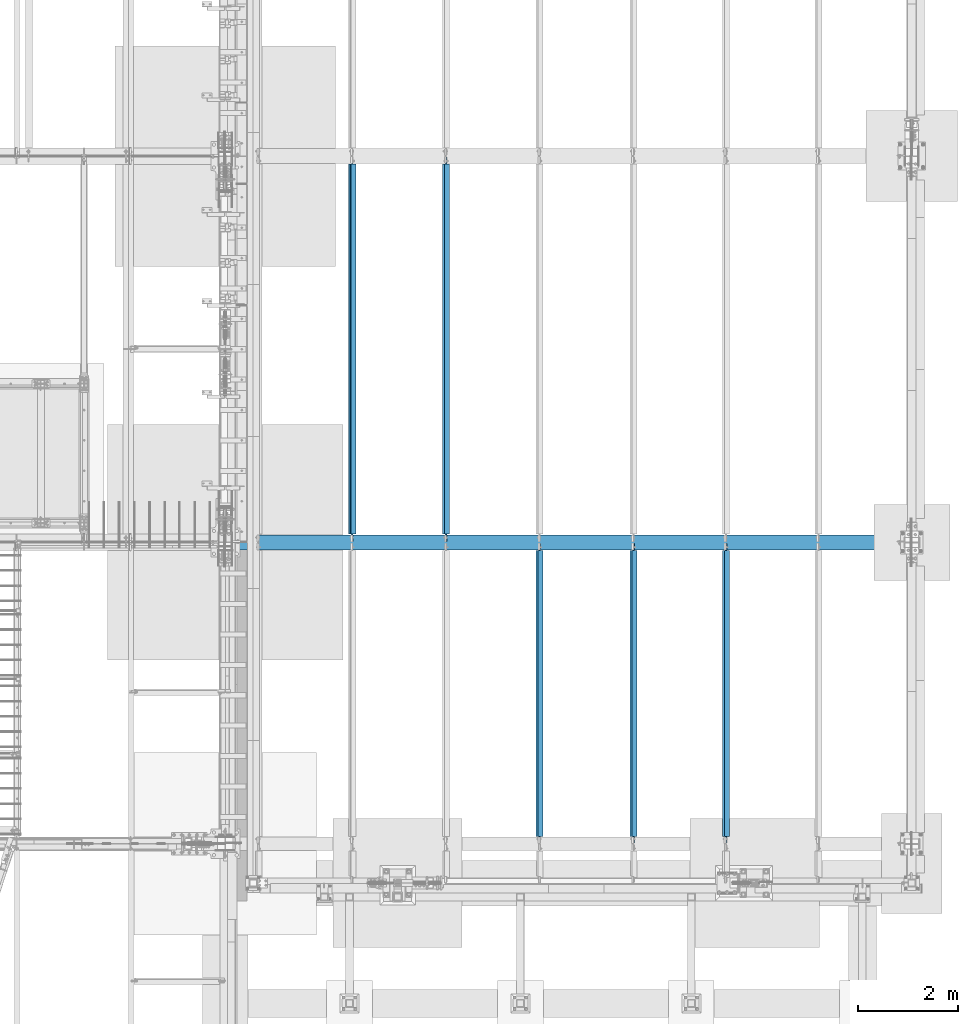
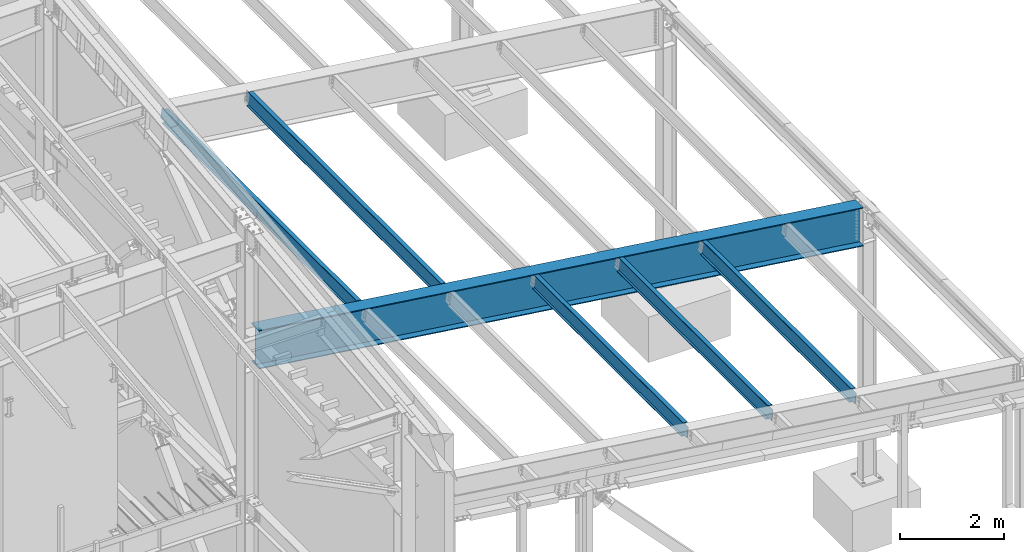
# One storey, part 747 of 1179: 6 beams, 6 elements without a shape of their own.
"""IFC2X3 building model written with IfcOpenShell, lengths in millimetres."""

import ifcopenshell
import ifcopenshell.guid

model = None  # the IFC model being written
_history = None  # IfcOwnerHistory: only IFC2X3 demands one
_inside = {}  # id of a spatial element -> (the spatial element, [elements in it])
_under = {}  # id of a project, library or spatial element -> (it, [spatial elements below it])
_declared = {}  # id of a project -> (the project, [libraries it declares])
_typed = {}  # id of a type object -> (the type object, [elements of that type])
_made_of = {}  # id of a material, layer set ... -> (it, [elements and type objects made of it])


def new_model(schema):
    """Start an empty IFC model of exactly this schema.

    Asked for "IFC4X3", IfcOpenShell would pick the latest addendum, in which some entities
    have other attributes; the version numbers below select the first issue.
    IFC2X3 requires an IfcOwnerHistory on every rooted entity: one is made here for all.
    """
    global model, _history
    if schema == "IFC4X3":
        model = ifcopenshell.file(schema_version=(4, 3, 0, 0))
    else:
        model = ifcopenshell.file(schema=schema)
    _inside.clear()
    _under.clear()
    _declared.clear()
    _typed.clear()
    _made_of.clear()
    _history = None
    if model.schema == "IFC2X3":
        org = make("IfcOrganization", Name="unknown")
        user = make(
            "IfcPersonAndOrganization",
            ThePerson=make("IfcPerson", FamilyName="unknown"),
            TheOrganization=org,
        )
        app = make(
            "IfcApplication",
            ApplicationDeveloper=org,
            Version="unknown",
            ApplicationFullName="unknown",
            ApplicationIdentifier="unknown",
        )
        _history = make(
            "IfcOwnerHistory",
            OwningUser=user,
            OwningApplication=app,
            ChangeAction="ADDED",
            CreationDate=0,
        )
    return model


def make(cls, **values):
    """One entity of the class cls with the attributes given. An attribute that is None is left unset."""
    return model.create_entity(
        cls, **{name: value for name, value in values.items() if value is not None}
    )


def rooted(cls, **values):
    """An entity with a GlobalId (a new one), such as an element, a storey or a relation."""
    return make(cls, GlobalId=ifcopenshell.guid.new(), OwnerHistory=_history, **values)


def si_unit(unit_type, name, prefix=None):
    """IfcSIUnit, for example si_unit("LENGTHUNIT", "METRE", prefix="MILLI")."""
    return make("IfcSIUnit", UnitType=unit_type, Prefix=prefix, Name=name)


def assignment(units):
    """IfcUnitAssignment: the units of a project."""
    return None if units is None else make("IfcUnitAssignment", Units=units)


def point(xyz):
    """IfcCartesianPoint."""
    return None if xyz is None else make("IfcCartesianPoint", Coordinates=xyz)


def direction(xyz):
    """IfcDirection."""
    return None if xyz is None else make("IfcDirection", DirectionRatios=xyz)


def frame(location, z_axis=None, x_axis=None):
    """IfcAxis2Placement3D, a coordinate frame: its origin and axes. An axis left out is left unset."""
    return make(
        "IfcAxis2Placement3D",
        Location=point(location),
        Axis=direction(z_axis),
        RefDirection=direction(x_axis),
    )


def origin_with_axes():
    """The frame at (0, 0, 0) with the z axis (0, 0, 1) and the x axis (1, 0, 0) written out."""
    return frame((0.0, 0.0, 0.0), z_axis=(0.0, 0.0, 1.0), x_axis=(1.0, 0.0, 0.0))


def place(relative_to, where):
    """IfcLocalPlacement: puts the frame where relative to a parent placement (None: the world)."""
    return make(
        "IfcLocalPlacement", PlacementRelTo=relative_to, RelativePlacement=where
    )


def context(
    kind, dimensions, precision=None, world=None, true_north=None, identifier=None
):
    """IfcGeometricRepresentationContext, for example the 3D "Model" context."""
    return make(
        "IfcGeometricRepresentationContext",
        ContextIdentifier=identifier,
        ContextType=kind,
        CoordinateSpaceDimension=dimensions,
        Precision=precision,
        WorldCoordinateSystem=world,
        TrueNorth=true_north,
    )


def subcontext(parent, identifier, kind, view, scale=None):
    """IfcGeometricRepresentationSubContext, for example "Body" below "Model"."""
    return make(
        "IfcGeometricRepresentationSubContext",
        ContextIdentifier=identifier,
        ContextType=kind,
        ParentContext=parent,
        TargetScale=scale,
        TargetView=view,
    )


def project(units=None, contexts=None):
    """IfcProject with its units and contexts."""
    return rooted(
        "IfcProject",
        Name="project",
        RepresentationContexts=contexts,
        UnitsInContext=assignment(units),
    )


def spatial(cls, under=None, at=None, **own):
    """A site, building, storey or space (cls), placed at a placement, below another one or the project."""
    s = rooted(cls, ObjectPlacement=at, **own)
    if under is not None:
        _under.setdefault(under.id(), (under, []))[1].append(s)
    return s


def faces_of(points, faces, orient=None, outer=None):
    """IfcFace entities. A face is a list of loops; a loop is a list of indices into points, from 0.

    orient and outer hold one flag for each loop. By default every Orientation is true, the
    first loop of a face is its IfcFaceOuterBound and the others are IfcFaceBound.
    """
    made = []
    for i, loops in enumerate(faces):
        bounds = []
        for j, loop in enumerate(loops):
            is_outer = j == 0 if outer is None else outer[i][j]
            bounds.append(
                make(
                    "IfcFaceOuterBound" if is_outer else "IfcFaceBound",
                    Bound=make("IfcPolyLoop", Polygon=[points[k] for k in loop]),
                    Orientation=True if orient is None else orient[i][j],
                )
            )
        made.append(make("IfcFace", Bounds=bounds))
    return made


def faceted_brep(points, faces, orient=None, outer=None, voids=None):
    """IfcFacetedBrep: a solid bounded by flat faces; with voids (closed shells), ...WithVoids."""
    shared = [point(p) for p in points]
    hull = make("IfcClosedShell", CfsFaces=faces_of(shared, faces, orient, outer))
    if voids is None:
        return make("IfcFacetedBrep", Outer=hull)
    return make(
        "IfcFacetedBrepWithVoids",
        Outer=hull,
        Voids=[
            make(cls, CfsFaces=faces_of(shared, fs, o, b)) for cls, fs, o, b in voids
        ],
    )


def shape(context_of_items, identifier, shape_type, items):
    """IfcShapeRepresentation: the items that make up one representation, for example the "Body"."""
    return make(
        "IfcShapeRepresentation",
        ContextOfItems=context_of_items,
        RepresentationIdentifier=identifier,
        RepresentationType=shape_type,
        Items=items,
    )


def material(Name=None, Category=None):
    """IfcMaterial."""
    return make("IfcMaterial", Name=Name, Category=Category)


def made_of(thing, what):
    """Note that an element or type object is made of a material, layer set ...; save() writes the relation."""
    if what is not None:
        _made_of.setdefault(what.id(), (what, []))[1].append(thing)
    return thing


def type_object(cls, material=None, **own):
    """A type object (cls), such as IfcWallType, which elements share."""
    return made_of(rooted(cls, **own), material)


def element(
    cls,
    number,
    at=None,
    inside=None,
    cuts=None,
    type_object=None,
    material=None,
    context=None,
    identifier="Body",
    shape_type=None,
    held_by="IfcProductDefinitionShape",
    body=None,
    shapes=None,
    **own,
):
    """One element of the class cls, such as IfcWall. Its Tag is "e" and its number.

    at: its placement. inside: the storey or other place that contains it. cuts: it is an
    opening in that element (IfcRelVoidsElement). A single representation is given by context,
    identifier, shape_type and body (its items); several are given by shapes. held_by: the class
    of the entity that holds the representations. save() writes the other relations.
    """
    e = rooted(cls, Tag="e%d" % number, ObjectPlacement=at, **own)
    if body is not None:
        shapes = [shape(context, identifier, shape_type, body)]
    if shapes is not None:
        e.Representation = make(held_by, Representations=shapes)
    if inside is not None:
        _inside.setdefault(inside.id(), (inside, []))[1].append(e)
    if cuts is not None:
        rooted(
            "IfcRelVoidsElement", RelatingBuildingElement=cuts, RelatedOpeningElement=e
        )
    if type_object is not None:
        _typed.setdefault(type_object.id(), (type_object, []))[1].append(e)
    return made_of(e, material)


def aggregate(whole, parts):
    """IfcRelAggregates: a whole, such as a stair, and the parts it consists of."""
    return rooted("IfcRelAggregates", RelatingObject=whole, RelatedObjects=parts)


def save(model, path):
    """Write the relations noted so far, then the file.

    IfcRelAggregates (storeys below a building ...), IfcRelContainedInSpatialStructure (elements
    in a storey), IfcRelDefinesByType, IfcRelAssociatesMaterial and IfcRelDeclares: one each for
    every whole, place, type object, material and project.
    """
    for whole, parts in _under.values():
        aggregate(whole, parts)
    for where, things in _inside.values():
        rooted(
            "IfcRelContainedInSpatialStructure",
            RelatedElements=things,
            RelatingStructure=where,
        )
    for kind, things in _typed.values():
        rooted("IfcRelDefinesByType", RelatedObjects=things, RelatingType=kind)
    for what, things in _made_of.values():
        rooted("IfcRelAssociatesMaterial", RelatedObjects=things, RelatingMaterial=what)
    for by, libraries in _declared.values():
        rooted("IfcRelDeclares", RelatingContext=by, RelatedDefinitions=libraries)
    model.write(path)


model = new_model("IFC2X3")

# Units and contexts
model_context = context("Model", 3, precision=1e-05, world=origin_with_axes())
body_context = subcontext(model_context, "Body", "Model", "MODEL_VIEW")
ifc_project = project(units=[si_unit("LENGTHUNIT", "METRE", prefix="MILLI"), si_unit("AREAUNIT", "SQUARE_METRE"), si_unit("VOLUMEUNIT", "CUBIC_METRE"), si_unit("MASSUNIT", "GRAM", prefix="KILO"), si_unit("TIMEUNIT", "SECOND"), si_unit("PLANEANGLEUNIT", "RADIAN"), si_unit("SOLIDANGLEUNIT", "STERADIAN"), si_unit("THERMODYNAMICTEMPERATUREUNIT", "DEGREE_CELSIUS"), si_unit("LUMINOUSINTENSITYUNIT", "LUMEN")], contexts=[model_context])

# Site, building, storey
site_placement = place(None, origin_with_axes())
site = spatial("IfcSite", under=ifc_project, at=site_placement, CompositionType="ELEMENT")
building_placement = place(site_placement, origin_with_axes())
building = spatial("IfcBuilding", under=site, at=building_placement, Name="Undefined", CompositionType="ELEMENT")
storey_placement = place(building_placement, origin_with_axes())
storey = spatial("IfcBuildingStorey", under=building, at=storey_placement, Name="Undefined", CompositionType="ELEMENT", Elevation=0.0)

# Assembly, beam
assembly_1_placement = place(storey_placement, origin_with_axes())
assembly_1 = element("IfcElementAssembly", 1, at=assembly_1_placement, inside=storey, Name="BEAM", AssemblyPlace="NOTDEFINED", PredefinedType="RIGID_FRAME")
ifc_material = material(Name="STEEL/A992")
beam_type_1 = type_object("IfcBeamType", Name="W12X22", PredefinedType="NOTDEFINED")
beam_1_placement = place(assembly_1_placement, frame((30611.5820076832, 5435.6, 7028.46481116712), z_axis=(0.133813223953133, 0.0, 0.991006569652931), x_axis=(0.0, 1.0, 0.0)))
beam_1 = element("IfcBeam", 2, at=beam_1_placement, type_object=beam_type_1, material=ifc_material, Name="BEAM", ObjectType="W12X22", context=body_context, shape_type="Brep", body=[
    faceted_brep([(5880.09999999999, -3.17499999983193, -144.462500000051), (5880.09999999999, -50.7999999998428, -144.462500000063), (5880.09999999999, -50.7999999998283, -155.575000000068), (5880.09999999999, 50.8000000001921, -155.575000000041), (5880.09999999999, 50.8000000001848, -144.462500000036), (5880.09999999999, 3.17500000017026, -144.462500000049), (5880.09999999999, 3.17500000016298, -136.52499982221), (5880.09999999999, -3.17499999983556, -136.524999822204), (5881.06672992258, 3.17500000015571, -131.66492030416), (5881.06672992258, -3.17499999984648, -131.664920304156), (5883.81974382306, 3.17500000015207, -127.544743836002), (5883.81974382306, -3.17499999985012, -127.544743835997), (5887.93992029121, 3.17500000014843, -124.791729935519), (5887.93992029121, -3.17499999985375, -124.791729935516), (5892.79999980926, 3.17500000014843, -123.825000012932), (5892.79999980926, -3.17499999985375, -123.825000012926), (6024.5625, -3.17499999985375, -123.825000012823), (6024.5625, 3.17500000014479, -123.825000012814), (144.4625, 3.17499999983193, 144.462500000049), (144.4625, 50.7999999998428, 144.462500000061), (5880.09999999999, 50.7999999998428, 144.462500000061), (5880.09999999999, 3.17499999983193, 144.462500000049), (146.049999999999, -3.1749999998392, -136.524999805057), (146.049999999999, 3.17500000015934, -136.52499980506), (146.049999999999, 3.17500000017026, -144.462500000049), (146.049999999999, 50.8000000001848, -144.462500000036), (146.049999999999, 50.8000000001921, -155.575000000041), (146.049999999999, -50.7999999998283, -155.575000000068), (146.049999999999, -50.7999999998428, -144.462500000063), (146.049999999999, -3.17499999983193, -144.462500000051), (145.083270077412, -3.17499999984284, -131.664920287005), (145.083270077412, 3.17500000015571, -131.664920287008), (142.330256176933, -3.17499999985012, -127.544743818849), (142.330256176933, 3.17500000015207, -127.544743818851), (138.21007970878, -3.17499999985375, -124.791729918366), (138.21007970878, 3.17500000014479, -124.791729918372), (133.350000190734, -3.17499999985375, -123.824999995779), (133.350000190734, 3.17500000014843, -123.824999995781), (19.0500000000002, -3.17499999985375, -123.824999995893), (19.0500000000002, 3.17500000014843, -123.824999995886), (19.0500000000002, -3.17500000013752, 117.475000004351), (19.0500000000002, 3.17499999986467, 117.475000004359), (131.762500190734, -3.17500000013752, 117.47500000447), (131.762500190734, 3.17499999986467, 117.475000004464), (136.62257970878, -3.17500000013752, 118.441729927057), (136.62257970878, 3.17499999986103, 118.441729927054), (140.742756176934, -3.17500000014115, 121.194743827538), (140.742756176934, 3.17499999986103, 121.194743827535), (143.495770077412, -3.17500000014479, 125.314920295696), (143.495770077412, 3.17499999985375, 125.314920295692), (144.4625, -3.17500000015571, 130.174999813746), (144.4625, 3.17499999984648, 130.174999813742), (144.4625, -50.8000000001921, 155.575000000039), (144.4625, 50.7999999998283, 155.575000000066), (144.4625, -3.17500000016662, 144.462500000047), (144.4625, -50.8000000001812, 144.462500000034), (5880.09999999999, -3.17500000016662, 144.462500000047), (5880.09999999999, -50.8000000001812, 144.462500000034), (5880.09999999999, -50.8000000001921, 155.575000000039), (5880.09999999999, 50.7999999998283, 155.575000000066), (5880.09999999999, -3.17500000015207, 130.17499979644), (5880.09999999999, 3.17499999985012, 130.174999796436), (5881.06672992258, -3.17500000014843, 125.314920278392), (5881.06672992258, 3.17499999985012, 125.314920278386), (5883.81974382306, -3.17500000014479, 121.194743810232), (5883.81974382306, 3.17499999985739, 121.194743810229), (5887.93992029121, -3.17500000013752, 118.441729909751), (5887.93992029121, 3.17499999986103, 118.441729909748), (5892.79999980926, -3.17500000013752, 117.474999987164), (5892.79999980926, 3.17499999986467, 117.474999987158), (6024.5625, -3.17500000013752, 117.474999987267), (6024.5625, 3.17499999986467, 117.474999987275)], [[[0, 1, 2, 3, 4, 5, 6, 7]], [[7, 6, 8, 9]], [[9, 8, 10, 11]], [[11, 10, 12, 13]], [[13, 12, 14, 15]], [[16, 15, 14, 17]], [[18, 19, 20, 21]], [[22, 23, 24, 25, 26, 27, 28, 29]], [[30, 31, 23, 22]], [[32, 33, 31, 30]], [[34, 35, 33, 32]], [[36, 37, 35, 34]], [[38, 39, 37, 36]], [[40, 41, 39, 38]], [[42, 43, 41, 40]], [[44, 45, 43, 42]], [[46, 47, 45, 44]], [[48, 49, 47, 46]], [[50, 51, 49, 48]], [[52, 53, 19, 18, 51, 50, 54, 55]], [[55, 54, 56, 57]], [[52, 55, 57, 58]], [[53, 52, 58, 59]], [[19, 53, 59, 20]], [[58, 57, 56, 60, 61, 21, 20, 59]], [[62, 63, 61, 60]], [[64, 65, 63, 62]], [[66, 67, 65, 64]], [[68, 69, 67, 66]], [[70, 71, 69, 68]], [[71, 70, 16, 17]], [[12, 10, 8, 6, 5, 24, 23, 31, 33, 35, 37, 39, 41, 43, 45, 47, 49, 51, 18, 21, 61, 63, 65, 67, 69, 71, 17, 14]], [[25, 24, 5, 4]], [[26, 25, 4, 3]], [[27, 26, 3, 2]], [[28, 27, 2, 1]], [[29, 28, 1, 0]], [[70, 68, 66, 64, 62, 60, 56, 54, 50, 48, 46, 44, 42, 40, 38, 36, 34, 32, 30, 22, 29, 0, 7, 9, 11, 13, 15, 16]]]),
])
aggregate(assembly_1, [beam_1])

assembly_2_placement = place(storey_placement, origin_with_axes())
assembly_2 = element("IfcElementAssembly", 3, at=assembly_2_placement, inside=storey, Name="BEAM", AssemblyPlace="NOTDEFINED", PredefinedType="RIGID_FRAME")
beam_2_placement = place(assembly_2_placement, frame((32491.1820076831, 5435.6, 6774.66696214919), z_axis=(0.133813223953133, 0.0, 0.991006569652931), x_axis=(0.0, 1.0, 0.0)))
beam_2 = element("IfcBeam", 4, at=beam_2_placement, type_object=beam_type_1, material=ifc_material, Name="BEAM", ObjectType="W12X22", context=body_context, shape_type="Brep", body=[
    faceted_brep([(5880.09999999999, -3.17499999983193, -144.462500000051), (5880.09999999999, -50.7999999998428, -144.462500000063), (5880.09999999999, -50.7999999998283, -155.575000000068), (5880.09999999999, 50.8000000001921, -155.575000000041), (5880.09999999999, 50.8000000001848, -144.462500000036), (5880.09999999999, 3.17500000017026, -144.462500000049), (5880.09999999999, 3.17500000016298, -136.52499982221), (5880.09999999999, -3.17499999983556, -136.524999822204), (5881.06672992258, 3.17500000015571, -131.66492030416), (5881.06672992258, -3.17499999984648, -131.664920304156), (5883.81974382306, 3.17500000015207, -127.544743836002), (5883.81974382306, -3.17499999985012, -127.544743835997), (5887.93992029121, 3.17500000014843, -124.791729935519), (5887.93992029121, -3.17499999985375, -124.791729935516), (5892.79999980926, 3.17500000014843, -123.825000012932), (5892.79999980926, -3.17499999985375, -123.825000012926), (6024.5625, -3.17499999985375, -123.825000012823), (6024.5625, 3.17500000014479, -123.825000012814), (144.4625, 3.17499999983193, 144.462500000049), (144.4625, 50.7999999998428, 144.462500000061), (5880.09999999999, 50.7999999998428, 144.462500000061), (5880.09999999999, 3.17499999983193, 144.462500000049), (146.049999999999, -3.1749999998392, -136.524999805057), (146.049999999999, 3.17500000015934, -136.52499980506), (146.049999999999, 3.17500000017026, -144.462500000049), (146.049999999999, 50.8000000001848, -144.462500000036), (146.049999999999, 50.8000000001921, -155.575000000041), (146.049999999999, -50.7999999998283, -155.575000000068), (146.049999999999, -50.7999999998428, -144.462500000063), (146.049999999999, -3.17499999983193, -144.462500000051), (145.083270077412, -3.17499999984284, -131.664920287005), (145.083270077412, 3.17500000015571, -131.664920287008), (142.330256176933, -3.17499999985012, -127.544743818849), (142.330256176933, 3.17500000015207, -127.544743818851), (138.21007970878, -3.17499999985375, -124.791729918366), (138.21007970878, 3.17500000014479, -124.791729918372), (133.350000190734, -3.17499999985375, -123.824999995779), (133.350000190734, 3.17500000014843, -123.824999995781), (19.0500000000002, -3.17499999985375, -123.824999995893), (19.0500000000002, 3.17500000014843, -123.824999995886), (19.0500000000002, -3.17500000013752, 117.475000004351), (19.0500000000002, 3.17499999986467, 117.475000004359), (131.762500190734, -3.17500000013752, 117.47500000447), (131.762500190734, 3.17499999986467, 117.475000004464), (136.62257970878, -3.17500000013752, 118.441729927057), (136.62257970878, 3.17499999986103, 118.441729927054), (140.742756176934, -3.17500000014115, 121.194743827538), (140.742756176934, 3.17499999986103, 121.194743827535), (143.495770077412, -3.17500000014479, 125.314920295696), (143.495770077412, 3.17499999985375, 125.314920295692), (144.4625, -3.17500000015571, 130.174999813746), (144.4625, 3.17499999984648, 130.174999813742), (144.4625, -50.8000000001921, 155.575000000039), (144.4625, 50.7999999998283, 155.575000000066), (144.4625, -3.17500000016662, 144.462500000047), (144.4625, -50.8000000001812, 144.462500000034), (5880.09999999999, -3.17500000016662, 144.462500000047), (5880.09999999999, -50.8000000001812, 144.462500000034), (5880.09999999999, -50.8000000001921, 155.575000000039), (5880.09999999999, 50.7999999998283, 155.575000000066), (5880.09999999999, -3.17500000015207, 130.17499979644), (5880.09999999999, 3.17499999985012, 130.174999796436), (5881.06672992258, -3.17500000014843, 125.314920278392), (5881.06672992258, 3.17499999985012, 125.314920278386), (5883.81974382306, -3.17500000014479, 121.194743810232), (5883.81974382306, 3.17499999985739, 121.194743810229), (5887.93992029121, -3.17500000013752, 118.441729909751), (5887.93992029121, 3.17499999986103, 118.441729909748), (5892.79999980926, -3.17500000013752, 117.474999987164), (5892.79999980926, 3.17499999986467, 117.474999987158), (6024.5625, -3.17500000013752, 117.474999987267), (6024.5625, 3.17499999986467, 117.474999987275)], [[[0, 1, 2, 3, 4, 5, 6, 7]], [[7, 6, 8, 9]], [[9, 8, 10, 11]], [[11, 10, 12, 13]], [[13, 12, 14, 15]], [[16, 15, 14, 17]], [[18, 19, 20, 21]], [[22, 23, 24, 25, 26, 27, 28, 29]], [[30, 31, 23, 22]], [[32, 33, 31, 30]], [[34, 35, 33, 32]], [[36, 37, 35, 34]], [[38, 39, 37, 36]], [[40, 41, 39, 38]], [[42, 43, 41, 40]], [[44, 45, 43, 42]], [[46, 47, 45, 44]], [[48, 49, 47, 46]], [[50, 51, 49, 48]], [[52, 53, 19, 18, 51, 50, 54, 55]], [[55, 54, 56, 57]], [[52, 55, 57, 58]], [[53, 52, 58, 59]], [[19, 53, 59, 20]], [[58, 57, 56, 60, 61, 21, 20, 59]], [[62, 63, 61, 60]], [[64, 65, 63, 62]], [[66, 67, 65, 64]], [[68, 69, 67, 66]], [[70, 71, 69, 68]], [[71, 70, 16, 17]], [[12, 10, 8, 6, 5, 24, 23, 31, 33, 35, 37, 39, 41, 43, 45, 47, 49, 51, 18, 21, 61, 63, 65, 67, 69, 71, 17, 14]], [[25, 24, 5, 4]], [[26, 25, 4, 3]], [[27, 26, 3, 2]], [[28, 27, 2, 1]], [[29, 28, 1, 0]], [[70, 68, 66, 64, 62, 60, 56, 54, 50, 48, 46, 44, 42, 40, 38, 36, 34, 32, 30, 22, 29, 0, 7, 9, 11, 13, 15, 16]]]),
])
aggregate(assembly_2, [beam_2])

assembly_3_placement = place(storey_placement, origin_with_axes())
assembly_3 = element("IfcElementAssembly", 5, at=assembly_3_placement, inside=storey, Name="BEAM", AssemblyPlace="NOTDEFINED", PredefinedType="RIGID_FRAME")
beam_3_placement = place(assembly_3_placement, frame((34345.3820076835, 5435.6, 6524.2988137938), z_axis=(0.133813223953133, 0.0, 0.991006569652931), x_axis=(0.0, 1.0, 0.0)))
beam_3 = element("IfcBeam", 6, at=beam_3_placement, type_object=beam_type_1, material=ifc_material, Name="BEAM", ObjectType="W12X22", context=body_context, shape_type="Brep", body=[
    faceted_brep([(5880.09999999999, -3.17499999983193, -144.462500000051), (5880.09999999999, -50.7999999998428, -144.462500000063), (5880.09999999999, -50.7999999998283, -155.575000000068), (5880.09999999999, 50.8000000001921, -155.575000000041), (5880.09999999999, 50.8000000001848, -144.462500000036), (5880.09999999999, 3.17500000017026, -144.462500000049), (5880.09999999999, 3.17500000016298, -136.52499982221), (5880.09999999999, -3.17499999983556, -136.524999822204), (5881.06672992258, 3.17500000015571, -131.66492030416), (5881.06672992258, -3.17499999984648, -131.664920304156), (5883.81974382306, 3.17500000015207, -127.544743836002), (5883.81974382306, -3.17499999985012, -127.544743835997), (5887.93992029121, 3.17500000014843, -124.791729935519), (5887.93992029121, -3.17499999985375, -124.791729935516), (5892.79999980926, 3.17500000014843, -123.825000012932), (5892.79999980926, -3.17499999985375, -123.825000012926), (6024.5625, -3.17499999985375, -123.825000012823), (6024.5625, 3.17500000014479, -123.825000012814), (144.4625, 3.17499999983193, 144.462500000049), (144.4625, 50.7999999998428, 144.462500000061), (5880.09999999999, 50.7999999998428, 144.462500000061), (5880.09999999999, 3.17499999983193, 144.462500000049), (146.049999999999, -3.1749999998392, -136.524999805057), (146.049999999999, 3.17500000015934, -136.52499980506), (146.049999999999, 3.17500000017026, -144.462500000049), (146.049999999999, 50.8000000001848, -144.462500000036), (146.049999999999, 50.8000000001921, -155.575000000041), (146.049999999999, -50.7999999998283, -155.575000000068), (146.049999999999, -50.7999999998428, -144.462500000063), (146.049999999999, -3.17499999983193, -144.462500000051), (145.083270077412, -3.17499999984284, -131.664920287005), (145.083270077412, 3.17500000015571, -131.664920287008), (142.330256176933, -3.17499999985012, -127.544743818849), (142.330256176933, 3.17500000015207, -127.544743818851), (138.21007970878, -3.17499999985375, -124.791729918366), (138.21007970878, 3.17500000014479, -124.791729918372), (133.350000190734, -3.17499999985375, -123.824999995779), (133.350000190734, 3.17500000014843, -123.824999995781), (19.0500000000002, -3.17499999985375, -123.824999995893), (19.0500000000002, 3.17500000014843, -123.824999995886), (19.0500000000002, -3.17500000013752, 117.475000004351), (19.0500000000002, 3.17499999986467, 117.475000004359), (131.762500190734, -3.17500000013752, 117.47500000447), (131.762500190734, 3.17499999986467, 117.475000004464), (136.62257970878, -3.17500000013752, 118.441729927057), (136.62257970878, 3.17499999986103, 118.441729927054), (140.742756176934, -3.17500000014115, 121.194743827538), (140.742756176934, 3.17499999986103, 121.194743827535), (143.495770077412, -3.17500000014479, 125.314920295696), (143.495770077412, 3.17499999985375, 125.314920295692), (144.4625, -3.17500000015571, 130.174999813746), (144.4625, 3.17499999984648, 130.174999813742), (144.4625, -50.8000000001921, 155.575000000039), (144.4625, 50.7999999998283, 155.575000000066), (144.4625, -3.17500000016662, 144.462500000047), (144.4625, -50.8000000001812, 144.462500000034), (5880.09999999999, -3.17500000016662, 144.462500000047), (5880.09999999999, -50.8000000001812, 144.462500000034), (5880.09999999999, -50.8000000001921, 155.575000000039), (5880.09999999999, 50.7999999998283, 155.575000000066), (5880.09999999999, -3.17500000015207, 130.17499979644), (5880.09999999999, 3.17499999985012, 130.174999796436), (5881.06672992258, -3.17500000014843, 125.314920278392), (5881.06672992258, 3.17499999985012, 125.314920278386), (5883.81974382306, -3.17500000014479, 121.194743810232), (5883.81974382306, 3.17499999985739, 121.194743810229), (5887.93992029121, -3.17500000013752, 118.441729909751), (5887.93992029121, 3.17499999986103, 118.441729909748), (5892.79999980926, -3.17500000013752, 117.474999987164), (5892.79999980926, 3.17499999986467, 117.474999987158), (6024.5625, -3.17500000013752, 117.474999987267), (6024.5625, 3.17499999986467, 117.474999987275)], [[[0, 1, 2, 3, 4, 5, 6, 7]], [[7, 6, 8, 9]], [[9, 8, 10, 11]], [[11, 10, 12, 13]], [[13, 12, 14, 15]], [[16, 15, 14, 17]], [[18, 19, 20, 21]], [[22, 23, 24, 25, 26, 27, 28, 29]], [[30, 31, 23, 22]], [[32, 33, 31, 30]], [[34, 35, 33, 32]], [[36, 37, 35, 34]], [[38, 39, 37, 36]], [[40, 41, 39, 38]], [[42, 43, 41, 40]], [[44, 45, 43, 42]], [[46, 47, 45, 44]], [[48, 49, 47, 46]], [[50, 51, 49, 48]], [[52, 53, 19, 18, 51, 50, 54, 55]], [[55, 54, 56, 57]], [[52, 55, 57, 58]], [[53, 52, 58, 59]], [[19, 53, 59, 20]], [[58, 57, 56, 60, 61, 21, 20, 59]], [[62, 63, 61, 60]], [[64, 65, 63, 62]], [[66, 67, 65, 64]], [[68, 69, 67, 66]], [[70, 71, 69, 68]], [[71, 70, 16, 17]], [[12, 10, 8, 6, 5, 24, 23, 31, 33, 35, 37, 39, 41, 43, 45, 47, 49, 51, 18, 21, 61, 63, 65, 67, 69, 71, 17, 14]], [[25, 24, 5, 4]], [[26, 25, 4, 3]], [[27, 26, 3, 2]], [[28, 27, 2, 1]], [[29, 28, 1, 0]], [[70, 68, 66, 64, 62, 60, 56, 54, 50, 48, 46, 44, 42, 40, 38, 36, 34, 32, 30, 22, 29, 0, 7, 9, 11, 13, 15, 16]]]),
])
aggregate(assembly_3, [beam_3])

assembly_4_placement = place(storey_placement, origin_with_axes())
assembly_4 = element("IfcElementAssembly", 7, at=assembly_4_placement, inside=storey, Name="BEAM", AssemblyPlace="NOTDEFINED", PredefinedType="RIGID_FRAME")
beam_4_placement = place(assembly_4_placement, frame((28731.9820076529, 11480.8, 7282.26266076169), z_axis=(0.133813223953133, 0.0, 0.991006569652931), x_axis=(0.0, 1.0, 0.0)))
beam_4 = element("IfcBeam", 8, at=beam_4_placement, type_object=beam_type_1, material=ifc_material, Name="BEAM", ObjectType="W12X22", context=body_context, shape_type="Brep", body=[
    faceted_brep([(7585.075, -3.17499999982829, -144.462500000047), (7585.075, -50.7999999998428, -144.46250000006), (7585.075, -50.7999999998356, -155.575000000064), (7585.075, 50.8000000001921, -155.575000000037), (7585.075, 50.8000000001775, -144.462500000032), (7585.075, 3.17500000017026, -144.462500000047), (7585.075, 3.17500000016298, -136.524999801413), (7585.075, -3.17499999984284, -136.52499980141), (7586.04172992259, 3.17500000014843, -131.664920283363), (7586.04172992259, -3.17499999984284, -131.66492028336), (7588.79474382307, 3.17500000014843, -127.544743815206), (7588.79474382307, -3.17499999985012, -127.544743815202), (7592.91492029122, 3.17500000014843, -124.791729914725), (7592.91492029122, -3.17499999985012, -124.791729914721), (7597.77499980927, 3.17500000014115, -123.824999992135), (7597.77499980927, -3.17499999985739, -123.824999992132), (7726.3625, -3.17499999985739, -123.824999992028), (7726.3625, 3.17500000014115, -123.824999992019), (165.100000000002, 3.17499999982829, 144.462500000052), (165.100000000002, 50.7999999998356, 144.462500000065), (7585.075, 50.7999999998356, 144.462500000065), (7585.075, 3.17499999982829, 144.462500000052), (165.100000000002, -3.17499999984284, -136.524999799762), (165.100000000002, 3.17500000016298, -136.524999799765), (165.100000000002, 3.17500000017026, -144.462500000047), (165.100000000002, 50.8000000001775, -144.462500000032), (165.100000000002, 50.8000000001921, -155.575000000037), (165.100000000002, -50.7999999998356, -155.575000000064), (165.100000000002, -50.7999999998428, -144.46250000006), (165.100000000002, -3.17499999982829, -144.462500000047), (164.133270077415, -3.17499999984284, -131.664920281712), (164.133270077415, 3.17500000014843, -131.664920281715), (161.380256176937, -3.17499999985739, -127.544743813552), (161.380256176937, 3.17500000014843, -127.544743813558), (157.260079708783, -3.17499999985739, -124.791729913073), (157.260079708783, 3.17500000014115, -124.791729913077), (152.400000190737, -3.17499999985739, -123.824999990484), (152.400000190737, 3.17500000014843, -123.824999990487), (20.6375000000044, -3.17499999985739, -123.824999990466), (20.6375000000044, 3.17500000014843, -123.824999990458), (20.6375000000044, -3.17500000014115, 117.475000009781), (20.6375000000044, 3.17499999986467, 117.475000009788), (152.400000190737, -3.17500000014115, 117.475000009763), (152.400000190737, 3.17499999985739, 117.475000009759), (157.260079708783, -3.17500000014115, 118.44172993235), (157.260079708783, 3.17499999986467, 118.441729932347), (161.380256176937, -3.17500000014115, 121.194743832832), (161.380256176937, 3.17499999985739, 121.194743832826), (164.133270077415, -3.17500000014843, 125.314920300991), (164.133270077415, 3.17499999985012, 125.314920300985), (165.100000000002, -3.17500000016298, 130.174999819041), (165.100000000002, 3.17499999984284, 130.174999819037), (165.100000000002, -50.8000000001994, 155.575000000043), (165.100000000002, 50.7999999998283, 155.57500000007), (165.100000000002, -3.17500000017753, 144.462500000051), (165.100000000002, -50.8000000001775, 144.462500000036), (7585.075, -3.17500000017753, 144.462500000051), (7585.075, -50.8000000001775, 144.462500000036), (7585.075, -50.8000000001994, 155.575000000043), (7585.075, 50.7999999998283, 155.57500000007), (7585.075, -3.17500000015571, 130.174999817393), (7585.075, 3.17499999985012, 130.174999817389), (7586.04172992259, -3.17500000015571, 125.314920299345), (7586.04172992259, 3.17499999985012, 125.314920299339), (7588.79474382307, -3.17500000014843, 121.194743831185), (7588.79474382307, 3.17499999985739, 121.194743831182), (7592.91492029122, -3.17500000014115, 118.441729930704), (7592.91492029122, 3.17499999986467, 118.441729930701), (7597.77499980927, -3.17500000014115, 117.475000008117), (7597.77499980927, 3.17499999986467, 117.475000008111), (7726.3625, -3.17500000014115, 117.47500000822), (7726.3625, 3.17499999985739, 117.475000008229)], [[[0, 1, 2, 3, 4, 5, 6, 7]], [[7, 6, 8, 9]], [[9, 8, 10, 11]], [[11, 10, 12, 13]], [[13, 12, 14, 15]], [[16, 15, 14, 17]], [[18, 19, 20, 21]], [[22, 23, 24, 25, 26, 27, 28, 29]], [[30, 31, 23, 22]], [[32, 33, 31, 30]], [[34, 35, 33, 32]], [[36, 37, 35, 34]], [[38, 39, 37, 36]], [[40, 41, 39, 38]], [[42, 43, 41, 40]], [[44, 45, 43, 42]], [[46, 47, 45, 44]], [[48, 49, 47, 46]], [[50, 51, 49, 48]], [[52, 53, 19, 18, 51, 50, 54, 55]], [[55, 54, 56, 57]], [[52, 55, 57, 58]], [[53, 52, 58, 59]], [[19, 53, 59, 20]], [[58, 57, 56, 60, 61, 21, 20, 59]], [[62, 63, 61, 60]], [[64, 65, 63, 62]], [[66, 67, 65, 64]], [[68, 69, 67, 66]], [[70, 71, 69, 68]], [[71, 70, 16, 17]], [[12, 10, 8, 6, 5, 24, 23, 31, 33, 35, 37, 39, 41, 43, 45, 47, 49, 51, 18, 21, 61, 63, 65, 67, 69, 71, 17, 14]], [[25, 24, 5, 4]], [[26, 25, 4, 3]], [[27, 26, 3, 2]], [[28, 27, 2, 1]], [[29, 28, 1, 0]], [[70, 68, 66, 64, 62, 60, 56, 54, 50, 48, 46, 44, 42, 40, 38, 36, 34, 32, 30, 22, 29, 0, 7, 9, 11, 13, 15, 16]]]),
])
aggregate(assembly_4, [beam_4])

assembly_5_placement = place(storey_placement, origin_with_axes())
assembly_5 = element("IfcElementAssembly", 9, at=assembly_5_placement, inside=storey, Name="BEAM", AssemblyPlace="NOTDEFINED", PredefinedType="RIGID_FRAME")
beam_5_placement = place(assembly_5_placement, frame((26852.382007655, 11480.8, 7536.06050951127), z_axis=(0.133813223953133, 0.0, 0.991006569652931), x_axis=(0.0, 1.0, 0.0)))
beam_5 = element("IfcBeam", 10, at=beam_5_placement, type_object=beam_type_1, material=ifc_material, Name="BEAM", ObjectType="W12X22", context=body_context, shape_type="Brep", body=[
    faceted_brep([(7585.075, -3.17499999982829, -144.462500000047), (7585.075, -50.7999999998428, -144.46250000006), (7585.075, -50.7999999998356, -155.575000000064), (7585.075, 50.8000000001921, -155.575000000037), (7585.075, 50.8000000001775, -144.462500000032), (7585.075, 3.17500000017026, -144.462500000047), (7585.075, 3.17500000016298, -136.524999801413), (7585.075, -3.17499999984284, -136.52499980141), (7586.04172992259, 3.17500000014843, -131.664920283363), (7586.04172992259, -3.17499999984284, -131.66492028336), (7588.79474382307, 3.17500000014843, -127.544743815206), (7588.79474382307, -3.17499999985012, -127.544743815202), (7592.91492029122, 3.17500000014843, -124.791729914725), (7592.91492029122, -3.17499999985012, -124.791729914721), (7597.77499980927, 3.17500000014115, -123.824999992135), (7597.77499980927, -3.17499999985739, -123.824999992132), (7726.3625, -3.17499999985739, -123.824999992028), (7726.3625, 3.17500000014115, -123.824999992019), (165.100000000002, 3.17499999982829, 144.462500000052), (165.100000000002, 50.7999999998356, 144.462500000065), (7585.075, 50.7999999998356, 144.462500000065), (7585.075, 3.17499999982829, 144.462500000052), (165.100000000002, -3.17499999984284, -136.524999799762), (165.100000000002, 3.17500000016298, -136.524999799765), (165.100000000002, 3.17500000017026, -144.462500000047), (165.100000000002, 50.8000000001775, -144.462500000032), (165.100000000002, 50.8000000001921, -155.575000000037), (165.100000000002, -50.7999999998356, -155.575000000064), (165.100000000002, -50.7999999998428, -144.46250000006), (165.100000000002, -3.17499999982829, -144.462500000047), (164.133270077415, -3.17499999984284, -131.664920281712), (164.133270077415, 3.17500000014843, -131.664920281715), (161.380256176937, -3.17499999985739, -127.544743813552), (161.380256176937, 3.17500000014843, -127.544743813558), (157.260079708783, -3.17499999985739, -124.791729913073), (157.260079708783, 3.17500000014115, -124.791729913077), (152.400000190737, -3.17499999985739, -123.824999990484), (152.400000190737, 3.17500000014843, -123.824999990487), (20.6375000000044, -3.17499999985739, -123.824999990466), (20.6375000000044, 3.17500000014843, -123.824999990458), (20.6375000000044, -3.17500000014115, 117.475000009781), (20.6375000000044, 3.17499999986467, 117.475000009788), (152.400000190737, -3.17500000014115, 117.475000009763), (152.400000190737, 3.17499999985739, 117.475000009759), (157.260079708783, -3.17500000014115, 118.44172993235), (157.260079708783, 3.17499999986467, 118.441729932347), (161.380256176937, -3.17500000014115, 121.194743832832), (161.380256176937, 3.17499999985739, 121.194743832826), (164.133270077415, -3.17500000014843, 125.314920300991), (164.133270077415, 3.17499999985012, 125.314920300985), (165.100000000002, -3.17500000016298, 130.174999819041), (165.100000000002, 3.17499999984284, 130.174999819037), (165.100000000002, -50.8000000001994, 155.575000000043), (165.100000000002, 50.7999999998283, 155.57500000007), (165.100000000002, -3.17500000017753, 144.462500000051), (165.100000000002, -50.8000000001775, 144.462500000036), (7585.075, -3.17500000017753, 144.462500000051), (7585.075, -50.8000000001775, 144.462500000036), (7585.075, -50.8000000001994, 155.575000000043), (7585.075, 50.7999999998283, 155.57500000007), (7585.075, -3.17500000015571, 130.174999817393), (7585.075, 3.17499999985012, 130.174999817389), (7586.04172992259, -3.17500000015571, 125.314920299345), (7586.04172992259, 3.17499999985012, 125.314920299339), (7588.79474382307, -3.17500000014843, 121.194743831185), (7588.79474382307, 3.17499999985739, 121.194743831182), (7592.91492029122, -3.17500000014115, 118.441729930704), (7592.91492029122, 3.17499999986467, 118.441729930701), (7597.77499980927, -3.17500000014115, 117.475000008117), (7597.77499980927, 3.17499999986467, 117.475000008111), (7726.3625, -3.17500000014115, 117.47500000822), (7726.3625, 3.17499999985739, 117.475000008229)], [[[0, 1, 2, 3, 4, 5, 6, 7]], [[7, 6, 8, 9]], [[9, 8, 10, 11]], [[11, 10, 12, 13]], [[13, 12, 14, 15]], [[16, 15, 14, 17]], [[18, 19, 20, 21]], [[22, 23, 24, 25, 26, 27, 28, 29]], [[30, 31, 23, 22]], [[32, 33, 31, 30]], [[34, 35, 33, 32]], [[36, 37, 35, 34]], [[38, 39, 37, 36]], [[40, 41, 39, 38]], [[42, 43, 41, 40]], [[44, 45, 43, 42]], [[46, 47, 45, 44]], [[48, 49, 47, 46]], [[50, 51, 49, 48]], [[52, 53, 19, 18, 51, 50, 54, 55]], [[55, 54, 56, 57]], [[52, 55, 57, 58]], [[53, 52, 58, 59]], [[19, 53, 59, 20]], [[58, 57, 56, 60, 61, 21, 20, 59]], [[62, 63, 61, 60]], [[64, 65, 63, 62]], [[66, 67, 65, 64]], [[68, 69, 67, 66]], [[70, 71, 69, 68]], [[71, 70, 16, 17]], [[12, 10, 8, 6, 5, 24, 23, 31, 33, 35, 37, 39, 41, 43, 45, 47, 49, 51, 18, 21, 61, 63, 65, 67, 69, 71, 17, 14]], [[25, 24, 5, 4]], [[26, 25, 4, 3]], [[27, 26, 3, 2]], [[28, 27, 2, 1]], [[29, 28, 1, 0]], [[70, 68, 66, 64, 62, 60, 56, 54, 50, 48, 46, 44, 42, 40, 38, 36, 34, 32, 30, 22, 29, 0, 7, 9, 11, 13, 15, 16]]]),
])
aggregate(assembly_5, [beam_5])

assembly_6_placement = place(storey_placement, origin_with_axes())
assembly_6 = element("IfcElementAssembly", 11, at=assembly_6_placement, inside=storey, Name="BEAM", AssemblyPlace="NOTDEFINED", PredefinedType="RIGID_FRAME")
beam_type_2 = type_object("IfcBeamType", Name="W36X135", PredefinedType="NOTDEFINED")
beam_6_placement = place(assembly_6_placement, frame((24247.4703078895, 11480.8, 7589.8408112643), z_axis=(0.133813223953133, 0.0, 0.991006569652931), x_axis=(0.99100656965293, 0.0, -0.133813223953134)))
beam_6 = element("IfcBeam", 12, at=beam_6_placement, type_object=beam_type_2, material=ifc_material, Name="BEAM", ObjectType="W36X135", context=body_context, shape_type="Brep", body=[
    faceted_brep([(293.15838363337, -152.4, -450.850000000231), (293.15838363337, 152.4, -450.850000000231), (13843.6866154603, 152.4, -450.850000003975), (13843.6866154603, -152.4, -450.850000003975), (290.37175184517, -152.4, -430.212500000223), (290.37175184517, -7.9375, -430.212500000223), (174.190641906149, -7.9375, 430.2125000001), (174.190641906149, -152.4, 430.2125000001), (171.404010117942, -152.4, 450.850000000108), (171.404010117942, 152.4, 450.850000000108), (174.190641906149, 152.4, 430.2125000001), (174.190641906149, 7.9375, 430.2125000001), (290.37175184517, 7.9375, -430.212500000223), (290.37175184517, 152.4, -430.212500000223), (13840.8999836721, -152.4, -430.212500003967), (13840.8999836721, -7.9375, -430.212500003967), (13724.7188737331, -7.9375, 430.212499996356), (13724.7188737331, -152.4, 430.212499996356), (13721.9322419449, -152.4, 450.849999996366), (13721.9322419449, 152.4, 450.849999996366), (13724.7188737331, 152.4, 430.212499996356), (13724.7188737331, 7.9375, 430.212499996356), (13840.8999836721, 7.9375, -430.212500003967), (13840.8999836721, 152.4, -430.212500003967)], [[[0, 1, 2, 3]], [[0, 4, 5, 6, 7, 8, 9, 10, 11, 12, 13, 1]], [[5, 4, 14, 15]], [[6, 5, 15, 16]], [[7, 6, 16, 17]], [[8, 7, 17, 18]], [[9, 8, 18, 19]], [[10, 9, 19, 20]], [[11, 10, 20, 21]], [[12, 11, 21, 22]], [[13, 12, 22, 23]], [[1, 13, 23, 2]], [[22, 21, 20, 19, 18, 17, 16, 15, 14, 3, 2, 23]], [[4, 0, 3, 14]]]),
])
aggregate(assembly_6, [beam_6])

save(model, "model.ifc")
